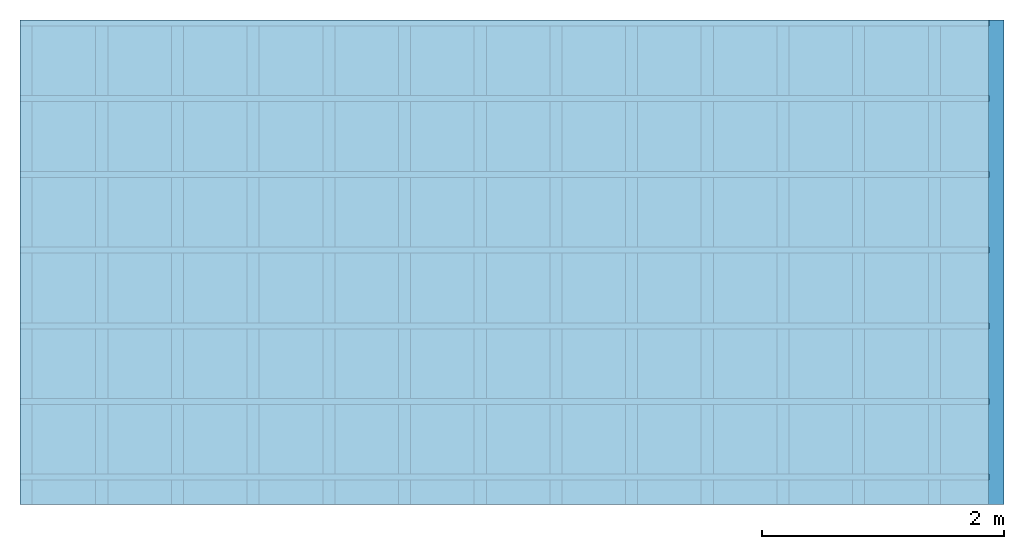
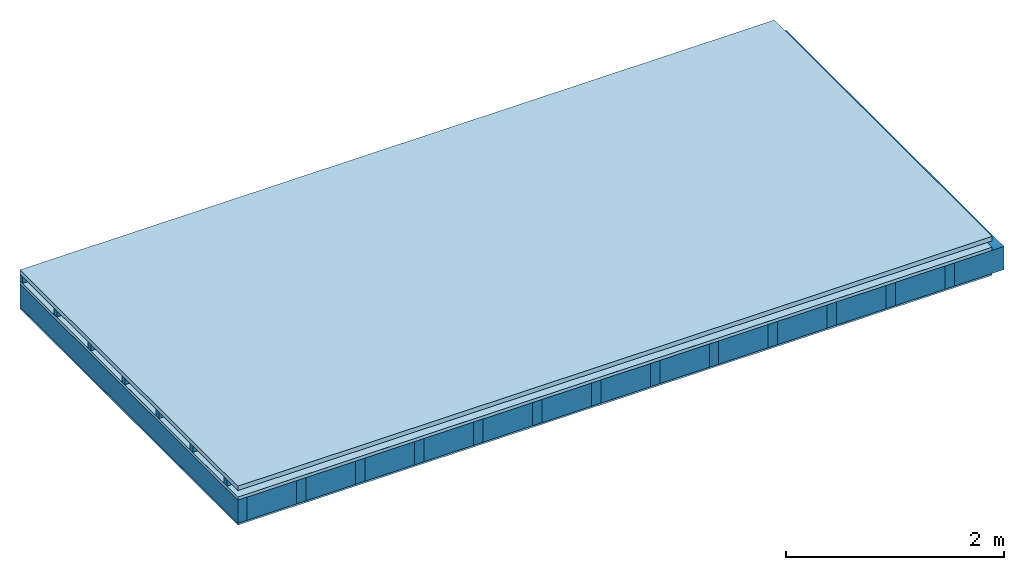
# One storey: 5 plates, 3 members, 1 element without a shape of its own.
"""IFC4 building model written with IfcOpenShell, lengths in metres."""

from ifc_helpers import new_model, si_unit, derived_unit, direction, frame, frame_2d, origin, origin_with_axes, place, context, project, spatial, rectangle, extrude, material, layer, layer_set, type_object, element, aggregate, save


model = new_model("IFC4")

# Units and contexts
plan_context = context("Plan", 3, precision=1e-05, world=origin(), true_north=direction((0.0, 1.0)))
model_context = context("Model", 3, precision=1e-05, world=origin(), true_north=direction((0.0, 1.0)))
ifc_project = project(units=[si_unit("LENGTHUNIT", "METRE"), derived_unit("SOUNDPRESSUREUNIT", [(si_unit("PRESSUREUNIT", "PASCAL", prefix="MICRO"), 0)]), si_unit("ENERGYUNIT", "JOULE", prefix="MEGA"), si_unit("MASSUNIT", "GRAM", prefix="KILO"), derived_unit("THERMALTRANSMITTANCEUNIT", [(si_unit("POWERUNIT", "WATT"), 1), (si_unit("AREAUNIT", "SQUARE_METRE"), -1), (si_unit("THERMODYNAMICTEMPERATUREUNIT", "KELVIN"), -1)]), derived_unit("AREADENSITYUNIT", [(si_unit("MASSUNIT", "GRAM", prefix="KILO"), 1), (si_unit("AREAUNIT", "SQUARE_METRE"), -1)]), derived_unit("USERDEFINED", [(si_unit("ENERGYUNIT", "JOULE", prefix="MEGA"), 1), (si_unit("AREAUNIT", "SQUARE_METRE"), -1)])], contexts=[plan_context, model_context])

# Site, building, storey
site = spatial("IfcSite", under=ifc_project)
building_placement = place(None, origin())
building = spatial("IfcBuilding", under=site, at=building_placement)
storey_placement = place(building_placement, origin())
storey = spatial("IfcBuildingStorey", under=building, at=storey_placement)

# Slab, members, plates
ifc_material_1 = material(Name="Roof tiles", Category="03.015")
ifc_layer_1 = layer(ifc_material_1, 0.05, Name="Roofing")
ifc_layer_2 = layer(None, 0.072, Name="Battens / profiles")
ifc_material_2 = material(Name="Roofing underlay", Category="09.008")
ifc_layer_3 = layer(ifc_material_2, 0.00018, Name="Under the roof")
ifc_material_3 = material(Category="10.009")
ifc_layer_4 = layer(ifc_material_3, 0.035, Name="Sub-floor")
ifc_material_4 = material(Name="of the art")
ifc_layer_5 = layer(ifc_material_4, 0.0, Name="Bond")
ifc_layer_6 = layer(None, 0.26, Name="Supporting structure")
ifc_material_5 = material(Name="Vapor barrier polyethylene (PE)", Category="09.002")
ifc_layer_7 = layer(ifc_material_5, 0.00025, Name="Vapor barrier")
ifc_material_6 = material(Name="3-layer panels", Category="07.001")
ifc_layer_8 = layer(ifc_material_6, 0.019, Name="Covering below 1st layer")
ifc_layer_set = layer_set([ifc_layer_1, ifc_layer_2, ifc_layer_3, ifc_layer_4, ifc_layer_5, ifc_layer_6, ifc_layer_7, ifc_layer_8])
slab_type = type_object("IfcSlabType", Name="E0184", PredefinedType="NOTDEFINED", material=ifc_layer_set)
slab_placement = place(None, frame((0.0, 0.0, 0.0), z_axis=(0.0, 0.0, -1.0), x_axis=(1.0, 0.0, 0.0)))
slab = element("IfcSlab", 1, at=slab_placement, inside=storey, type_object=slab_type, material=ifc_layer_set, Name="Slab #1")
ifc_material_7 = material()
member_1_placement = place(slab_placement, origin())
member_1 = element("IfcMember", 2, at=member_1_placement, material=ifc_material_7, Name="Battens / profiles", context=plan_context, shape_type="SweptSolid", body=[
    extrude(rectangle(XDim=0.05, YDim=0.072, at=frame_2d((0.025, 0.036), x_axis=(1.0, 0.0))), frame((0.0, 0.0, 0.05), z_axis=(1.0, 0.0, 0.0), x_axis=(0.0, 1.0, 0.0)), (0.0, 0.0, 1.0), 8.0),
    extrude(rectangle(XDim=0.05, YDim=0.072, at=frame_2d((0.025, 0.036), x_axis=(1.0, 0.0))), frame((0.0, 0.625, 0.05), z_axis=(1.0, 0.0, 0.0), x_axis=(0.0, 1.0, 0.0)), (0.0, 0.0, 1.0), 8.0),
    extrude(rectangle(XDim=0.05, YDim=0.072, at=frame_2d((0.025, 0.036), x_axis=(1.0, 0.0))), frame((0.0, 1.25, 0.05), z_axis=(1.0, 0.0, 0.0), x_axis=(0.0, 1.0, 0.0)), (0.0, 0.0, 1.0), 8.0),
    extrude(rectangle(XDim=0.05, YDim=0.072, at=frame_2d((0.025, 0.036), x_axis=(1.0, 0.0))), frame((0.0, 1.875, 0.05), z_axis=(1.0, 0.0, 0.0), x_axis=(0.0, 1.0, 0.0)), (0.0, 0.0, 1.0), 8.0),
    extrude(rectangle(XDim=0.05, YDim=0.072, at=frame_2d((0.025, 0.036), x_axis=(1.0, 0.0))), frame((0.0, 2.5, 0.05), z_axis=(1.0, 0.0, 0.0), x_axis=(0.0, 1.0, 0.0)), (0.0, 0.0, 1.0), 8.0),
    extrude(rectangle(XDim=0.05, YDim=0.072, at=frame_2d((0.025, 0.036), x_axis=(1.0, 0.0))), frame((0.0, 3.125, 0.05), z_axis=(1.0, 0.0, 0.0), x_axis=(0.0, 1.0, 0.0)), (0.0, 0.0, 1.0), 8.0),
    extrude(rectangle(XDim=0.05, YDim=0.072, at=frame_2d((0.025, 0.036), x_axis=(1.0, 0.0))), frame((0.0, 3.75, 0.05), z_axis=(1.0, 0.0, 0.0), x_axis=(0.0, 1.0, 0.0)), (0.0, 0.0, 1.0), 8.0),
])
ifc_material_8 = material()
member_2_placement = place(slab_placement, origin())
member_2 = element("IfcMember", 3, at=member_2_placement, material=ifc_material_8, Name="Supporting structure", context=plan_context, shape_type="SweptSolid", body=[
    extrude(rectangle(XDim=0.1, YDim=0.26, at=frame_2d((0.05, 0.13), x_axis=(1.0, 0.0))), frame((0.0, 4.0, 0.15718), z_axis=(0.0, -1.0, 0.0), x_axis=(1.0, 0.0, 0.0)), (0.0, 0.0, 1.0), 4.0),
    extrude(rectangle(XDim=0.1, YDim=0.26, at=frame_2d((0.05, 0.13), x_axis=(1.0, 0.0))), frame((0.625, 4.0, 0.15718), z_axis=(0.0, -1.0, 0.0), x_axis=(1.0, 0.0, 0.0)), (0.0, 0.0, 1.0), 4.0),
    extrude(rectangle(XDim=0.1, YDim=0.26, at=frame_2d((0.05, 0.13), x_axis=(1.0, 0.0))), frame((1.25, 4.0, 0.15718), z_axis=(0.0, -1.0, 0.0), x_axis=(1.0, 0.0, 0.0)), (0.0, 0.0, 1.0), 4.0),
    extrude(rectangle(XDim=0.1, YDim=0.26, at=frame_2d((0.05, 0.13), x_axis=(1.0, 0.0))), frame((1.875, 4.0, 0.15718), z_axis=(0.0, -1.0, 0.0), x_axis=(1.0, 0.0, 0.0)), (0.0, 0.0, 1.0), 4.0),
    extrude(rectangle(XDim=0.1, YDim=0.26, at=frame_2d((0.05, 0.13), x_axis=(1.0, 0.0))), frame((2.5, 4.0, 0.15718), z_axis=(0.0, -1.0, 0.0), x_axis=(1.0, 0.0, 0.0)), (0.0, 0.0, 1.0), 4.0),
    extrude(rectangle(XDim=0.1, YDim=0.26, at=frame_2d((0.05, 0.13), x_axis=(1.0, 0.0))), frame((3.125, 4.0, 0.15718), z_axis=(0.0, -1.0, 0.0), x_axis=(1.0, 0.0, 0.0)), (0.0, 0.0, 1.0), 4.0),
    extrude(rectangle(XDim=0.1, YDim=0.26, at=frame_2d((0.05, 0.13), x_axis=(1.0, 0.0))), frame((3.75, 4.0, 0.15718), z_axis=(0.0, -1.0, 0.0), x_axis=(1.0, 0.0, 0.0)), (0.0, 0.0, 1.0), 4.0),
    extrude(rectangle(XDim=0.1, YDim=0.26, at=frame_2d((0.05, 0.13), x_axis=(1.0, 0.0))), frame((4.375, 4.0, 0.15718), z_axis=(0.0, -1.0, 0.0), x_axis=(1.0, 0.0, 0.0)), (0.0, 0.0, 1.0), 4.0),
    extrude(rectangle(XDim=0.1, YDim=0.26, at=frame_2d((0.05, 0.13), x_axis=(1.0, 0.0))), frame((5.0, 4.0, 0.15718), z_axis=(0.0, -1.0, 0.0), x_axis=(1.0, 0.0, 0.0)), (0.0, 0.0, 1.0), 4.0),
    extrude(rectangle(XDim=0.1, YDim=0.26, at=frame_2d((0.05, 0.13), x_axis=(1.0, 0.0))), frame((5.625, 4.0, 0.15718), z_axis=(0.0, -1.0, 0.0), x_axis=(1.0, 0.0, 0.0)), (0.0, 0.0, 1.0), 4.0),
    extrude(rectangle(XDim=0.1, YDim=0.26, at=frame_2d((0.05, 0.13), x_axis=(1.0, 0.0))), frame((6.25, 4.0, 0.15718), z_axis=(0.0, -1.0, 0.0), x_axis=(1.0, 0.0, 0.0)), (0.0, 0.0, 1.0), 4.0),
    extrude(rectangle(XDim=0.1, YDim=0.26, at=frame_2d((0.05, 0.13), x_axis=(1.0, 0.0))), frame((6.875, 4.0, 0.15718), z_axis=(0.0, -1.0, 0.0), x_axis=(1.0, 0.0, 0.0)), (0.0, 0.0, 1.0), 4.0),
    extrude(rectangle(XDim=0.1, YDim=0.26, at=frame_2d((0.05, 0.13), x_axis=(1.0, 0.0))), frame((7.5, 4.0, 0.15718), z_axis=(0.0, -1.0, 0.0), x_axis=(1.0, 0.0, 0.0)), (0.0, 0.0, 1.0), 4.0),
])
ifc_material_9 = material(Name="Mineral wool")
member_3_placement = place(slab_placement, origin())
member_3 = element("IfcMember", 4, at=member_3_placement, material=ifc_material_9, Name="Cavity", context=plan_context, shape_type="SweptSolid", body=[
    extrude(rectangle(XDim=0.525, YDim=0.26, at=frame_2d((0.2625, 0.13), x_axis=(1.0, 0.0))), frame((0.1, 4.0, 0.15718), z_axis=(0.0, -1.0, 0.0), x_axis=(1.0, 0.0, 0.0)), (0.0, 0.0, 1.0), 4.0),
    extrude(rectangle(XDim=0.525, YDim=0.26, at=frame_2d((0.2625, 0.13), x_axis=(1.0, 0.0))), frame((0.725, 4.0, 0.15718), z_axis=(0.0, -1.0, 0.0), x_axis=(1.0, 0.0, 0.0)), (0.0, 0.0, 1.0), 4.0),
    extrude(rectangle(XDim=0.525, YDim=0.26, at=frame_2d((0.2625, 0.13), x_axis=(1.0, 0.0))), frame((1.35, 4.0, 0.15718), z_axis=(0.0, -1.0, 0.0), x_axis=(1.0, 0.0, 0.0)), (0.0, 0.0, 1.0), 4.0),
    extrude(rectangle(XDim=0.525, YDim=0.26, at=frame_2d((0.2625, 0.13), x_axis=(1.0, 0.0))), frame((1.975, 4.0, 0.15718), z_axis=(0.0, -1.0, 0.0), x_axis=(1.0, 0.0, 0.0)), (0.0, 0.0, 1.0), 4.0),
    extrude(rectangle(XDim=0.525, YDim=0.26, at=frame_2d((0.2625, 0.13), x_axis=(1.0, 0.0))), frame((2.6, 4.0, 0.15718), z_axis=(0.0, -1.0, 0.0), x_axis=(1.0, 0.0, 0.0)), (0.0, 0.0, 1.0), 4.0),
    extrude(rectangle(XDim=0.525, YDim=0.26, at=frame_2d((0.2625, 0.13), x_axis=(1.0, 0.0))), frame((3.225, 4.0, 0.15718), z_axis=(0.0, -1.0, 0.0), x_axis=(1.0, 0.0, 0.0)), (0.0, 0.0, 1.0), 4.0),
    extrude(rectangle(XDim=0.525, YDim=0.26, at=frame_2d((0.2625, 0.13), x_axis=(1.0, 0.0))), frame((3.85, 4.0, 0.15718), z_axis=(0.0, -1.0, 0.0), x_axis=(1.0, 0.0, 0.0)), (0.0, 0.0, 1.0), 4.0),
    extrude(rectangle(XDim=0.525, YDim=0.26, at=frame_2d((0.2625, 0.13), x_axis=(1.0, 0.0))), frame((4.475, 4.0, 0.15718), z_axis=(0.0, -1.0, 0.0), x_axis=(1.0, 0.0, 0.0)), (0.0, 0.0, 1.0), 4.0),
    extrude(rectangle(XDim=0.525, YDim=0.26, at=frame_2d((0.2625, 0.13), x_axis=(1.0, 0.0))), frame((5.1, 4.0, 0.15718), z_axis=(0.0, -1.0, 0.0), x_axis=(1.0, 0.0, 0.0)), (0.0, 0.0, 1.0), 4.0),
    extrude(rectangle(XDim=0.525, YDim=0.26, at=frame_2d((0.2625, 0.13), x_axis=(1.0, 0.0))), frame((5.725, 4.0, 0.15718), z_axis=(0.0, -1.0, 0.0), x_axis=(1.0, 0.0, 0.0)), (0.0, 0.0, 1.0), 4.0),
    extrude(rectangle(XDim=0.525, YDim=0.26, at=frame_2d((0.2625, 0.13), x_axis=(1.0, 0.0))), frame((6.35, 4.0, 0.15718), z_axis=(0.0, -1.0, 0.0), x_axis=(1.0, 0.0, 0.0)), (0.0, 0.0, 1.0), 4.0),
    extrude(rectangle(XDim=0.525, YDim=0.26, at=frame_2d((0.2625, 0.13), x_axis=(1.0, 0.0))), frame((6.975, 4.0, 0.15718), z_axis=(0.0, -1.0, 0.0), x_axis=(1.0, 0.0, 0.0)), (0.0, 0.0, 1.0), 4.0),
    extrude(rectangle(XDim=0.525, YDim=0.26, at=frame_2d((0.2625, 0.13), x_axis=(1.0, 0.0))), frame((7.6, 4.0, 0.15718), z_axis=(0.0, -1.0, 0.0), x_axis=(1.0, 0.0, 0.0)), (0.0, 0.0, 1.0), 4.0),
])
plate_1_placement = place(slab_placement, origin())
plate_1 = element("IfcPlate", 5, at=plate_1_placement, material=ifc_material_1, Name="Roofing", context=plan_context, shape_type="SweptSolid", body=[
    extrude(rectangle(XDim=8.0, YDim=4.0, at=frame_2d((4.0, 2.0), x_axis=(1.0, 0.0))), origin_with_axes(), (0.0, 0.0, 1.0), 0.05),
])
plate_2_placement = place(slab_placement, origin())
plate_2 = element("IfcPlate", 6, at=plate_2_placement, material=ifc_material_2, Name="Under the roof", context=plan_context, shape_type="SweptSolid", body=[
    extrude(rectangle(XDim=8.0, YDim=4.0, at=frame_2d((4.0, 2.0), x_axis=(1.0, 0.0))), frame((0.0, 0.0, 0.122), z_axis=(0.0, 0.0, 1.0), x_axis=(1.0, 0.0, 0.0)), (0.0, 0.0, 1.0), 0.00018),
])
plate_3_placement = place(slab_placement, origin())
plate_3 = element("IfcPlate", 7, at=plate_3_placement, material=ifc_material_3, Name="Sub-floor", context=plan_context, shape_type="SweptSolid", body=[
    extrude(rectangle(XDim=8.0, YDim=4.0, at=frame_2d((4.0, 2.0), x_axis=(1.0, 0.0))), frame((0.0, 0.0, 0.12218), z_axis=(0.0, 0.0, 1.0), x_axis=(1.0, 0.0, 0.0)), (0.0, 0.0, 1.0), 0.035),
])
plate_4_placement = place(slab_placement, origin())
plate_4 = element("IfcPlate", 8, at=plate_4_placement, material=ifc_material_5, Name="Vapor barrier", context=plan_context, shape_type="SweptSolid", body=[
    extrude(rectangle(XDim=8.0, YDim=4.0, at=frame_2d((4.0, 2.0), x_axis=(1.0, 0.0))), frame((0.0, 0.0, 0.41718), z_axis=(0.0, 0.0, 1.0), x_axis=(1.0, 0.0, 0.0)), (0.0, 0.0, 1.0), 0.00025),
])
plate_5_placement = place(slab_placement, origin())
plate_5 = element("IfcPlate", 9, at=plate_5_placement, material=ifc_material_6, Name="Covering below 1st layer", context=plan_context, shape_type="SweptSolid", body=[
    extrude(rectangle(XDim=8.0, YDim=4.0, at=frame_2d((4.0, 2.0), x_axis=(1.0, 0.0))), frame((0.0, 0.0, 0.41743), z_axis=(0.0, 0.0, 1.0), x_axis=(1.0, 0.0, 0.0)), (0.0, 0.0, 1.0), 0.019),
])
aggregate(slab, [plate_1, member_1, plate_2, plate_3, member_2, member_3, plate_4, plate_5])

save(model, "model.ifc")
